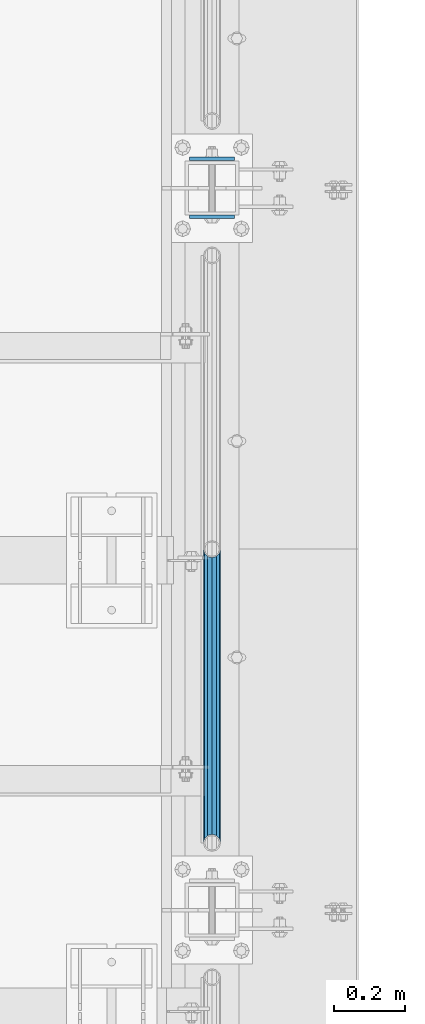
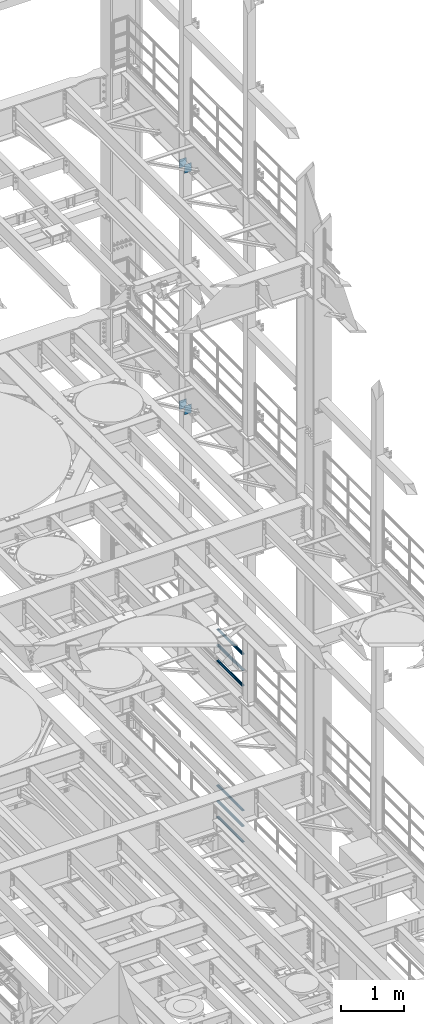
# One storey, part 1346 of 1876: 10 beams, 4 elements without a shape of their own.
"""IFC2X3 building model written with IfcOpenShell, lengths in millimetres."""

from ifc_helpers import new_model, si_unit, frame, origin_with_axes, place, context, subcontext, project, spatial, faceted_brep, material, type_object, element, aggregate, save


model = new_model("IFC2X3")

# Units and contexts
model_context = context("Model", 3, precision=1e-05, world=origin_with_axes())
body_context = subcontext(model_context, "Body", "Model", "MODEL_VIEW")
ifc_project = project(units=[si_unit("LENGTHUNIT", "METRE", prefix="MILLI"), si_unit("AREAUNIT", "SQUARE_METRE"), si_unit("VOLUMEUNIT", "CUBIC_METRE"), si_unit("MASSUNIT", "GRAM", prefix="KILO"), si_unit("TIMEUNIT", "SECOND"), si_unit("PLANEANGLEUNIT", "RADIAN"), si_unit("SOLIDANGLEUNIT", "STERADIAN"), si_unit("THERMODYNAMICTEMPERATUREUNIT", "DEGREE_CELSIUS"), si_unit("LUMINOUSINTENSITYUNIT", "LUMEN")], contexts=[model_context])

# Site, building, storey
site_placement = place(None, origin_with_axes())
site = spatial("IfcSite", under=ifc_project, at=site_placement, CompositionType="ELEMENT")
building_placement = place(site_placement, origin_with_axes())
building = spatial("IfcBuilding", under=site, at=building_placement, Name="Undefined", CompositionType="ELEMENT")
storey_placement = place(building_placement, origin_with_axes())
storey = spatial("IfcBuildingStorey", under=building, at=storey_placement, Name="Undefined", CompositionType="ELEMENT", Elevation=0.0)

# Assembly, beams
assembly_1_placement = place(storey_placement, origin_with_axes())
assembly_1 = element("IfcElementAssembly", 1, at=assembly_1_placement, inside=storey, Name="RAIL", AssemblyPlace="NOTDEFINED", PredefinedType="RIGID_FRAME")
ifc_material_1 = material()
beam_type_1 = type_object("IfcBeamType", Name="PIPE1-1/2SCH40", PredefinedType="NOTDEFINED")
beam_1_placement = place(assembly_1_placement, frame((7620.0, 10668.0, 8315.325), z_axis=(0.0, 0.0, 1.0), x_axis=(0.0, -1.0, 0.0)))
beam_1 = element("IfcBeam", 2, at=beam_1_placement, type_object=beam_type_1, material=ifc_material_1, Name="RAIL", ObjectType="PIPE1-1/2SCH40", context=body_context, shape_type="Brep", body=[
    faceted_brep([(805.872807006681, -12.0649999999996, 20.8971929933177), (805.872807006683, -12.0649999999996, 15.8661214311796), (805.379378568819, -10.2235000000001, 17.7076214311819), (802.640000000001, 0.0, 20.4470000000001), (802.640000000001, 0.0, 24.130000000001), (805.379378568819, 10.2235000000001, 17.7076214311819), (805.872807006683, 12.0649999999996, 15.8661214311796), (805.872807006681, 12.0649999999996, 20.8971929933177), (826.77, 24.1300000000001, 0.0), (814.705, 20.8971929933186, 12.0649999999987), (814.705, 20.8971929933186, -12.0649999999987), (811.515428437862, 17.7076214311801, 10.2235000000001), (814.254807006682, 20.4470000000001, 0.0), (811.515428437862, 17.7076214311801, -10.2235000000001), (805.872807006683, 12.0649999999996, -15.8661214311796), (805.872807006681, 12.0649999999996, -20.8971929933177), (805.379378568819, 10.2235000000001, -17.7076214311819), (802.640000000001, 0.0, -20.4470000000001), (802.640000000001, 0.0, -24.130000000001), (805.872807006683, -12.0649999999996, -15.8661214311796), (805.872807006681, -12.0649999999996, -20.8971929933177), (805.379378568819, -10.2235000000001, -17.7076214311819), (826.77, -24.1300000000001, 0.0), (814.705, -20.8971929933186, -12.0649999999987), (814.705, -20.8971929933186, 12.0649999999987), (811.515428437862, -17.7076214311801, -10.2235000000001), (814.254807006682, -20.4470000000001, 0.0), (811.515428437862, -17.7076214311801, 10.2235000000001), (12.0650000000064, -20.8971929933177, -12.0649999999987), (20.8971929933249, -12.0650000000005, -20.8971929933177), (0.0, 24.1299999999992, 0.0), (12.0650000000064, 20.8971929933177, -12.0649999999987), (12.0650000000064, 20.8971929933177, 12.0649999999987), (20.8971929933249, 12.0650000000005, 20.8971929933177), (24.1300000000064, 0.0, 24.130000000001), (20.8971929933249, 12.0650000000005, -20.8971929933177), (24.1300000000063, 0.0, -24.130000000001), (24.1300000000063, 0.0, -20.4470000000001), (20.8971929933249, -12.0650000000005, -15.8661214311796), (21.3906214311868, -10.2235000000001, -17.7076214311819), (21.3906214311868, 10.2235000000001, -17.7076214311819), (20.8971929933249, 12.0650000000005, -15.8661214311796), (15.2545715621445, 17.7076214311801, -10.2235000000001), (12.5151929933249, 20.4470000000001, 0.0), (15.2545715621445, 17.7076214311801, 10.2235000000001), (20.8971929933249, 12.0650000000005, 15.8661214311796), (21.3906214311868, 10.2235000000001, 17.7076214311819), (24.1300000000064, 0.0, 20.4470000000001), (21.3906214311868, -10.2235000000001, 17.7076214311819), (20.8971929933249, -12.0650000000005, 15.8661214311796), (20.8971929933249, -12.0650000000005, 20.8971929933177), (12.0650000000064, -20.8971929933177, 12.0649999999987), (0.0, -24.1299999999992, 0.0), (15.2545715621445, -17.7076214311801, 10.2235000000001), (12.5151929933249, -20.4470000000001, 0.0), (15.2545715621445, -17.7076214311801, -10.2235000000001)], [[[0, 1, 2, 3, 4]], [[4, 3, 5, 6, 7]], [[8, 9, 10]], [[7, 6, 11, 12, 13, 14, 15, 10, 9]], [[16, 17, 18, 15, 14]], [[19, 20, 18, 17, 21]], [[22, 23, 24]], [[24, 23, 20, 19, 25, 26, 27, 1, 0]], [[28, 29, 20, 23]], [[30, 31, 32]], [[33, 34, 4, 7]], [[32, 33, 7, 9]], [[30, 32, 9, 8]], [[31, 30, 8, 10]], [[35, 31, 10, 15]], [[36, 35, 15, 18]], [[29, 36, 18, 20]], [[37, 36, 29, 38, 39]], [[40, 41, 35, 36, 37]], [[32, 31, 35, 41, 42, 43, 44, 45, 33]], [[33, 45, 46, 47, 34]], [[34, 47, 48, 49, 50]], [[34, 50, 0, 4]], [[50, 51, 24, 0]], [[51, 52, 22, 24]], [[52, 28, 23, 22]], [[51, 28, 52]], [[50, 49, 53, 54, 55, 38, 29, 28, 51]], [[55, 54, 26, 25]], [[21, 39, 38, 55, 25, 19]], [[37, 39, 21, 17]], [[40, 37, 17, 16]], [[42, 41, 40, 16, 14, 13]], [[43, 42, 13, 12]], [[44, 43, 12, 11]], [[5, 46, 45, 44, 11, 6]], [[47, 46, 5, 3]], [[48, 47, 3, 2]], [[53, 49, 48, 2, 1, 27]], [[54, 53, 27, 26]]]),
])
beam_2_placement = place(assembly_1_placement, frame((7620.0, 9841.23, 8620.125), z_axis=(0.0, 0.0, -1.0), x_axis=(0.0, 1.0, 0.0)))
beam_2 = element("IfcBeam", 3, at=beam_2_placement, type_object=beam_type_1, material=ifc_material_1, Name="RAIL", ObjectType="PIPE1-1/2SCH40", context=body_context, shape_type="Brep", body=[
    faceted_brep([(0.0, 24.1299999999992, 0.0), (12.0650000000064, 20.8971929933177, -12.0649999999987), (12.0650000000064, 20.8971929933177, 12.0649999999987), (12.0650000000064, -20.8971929933177, 12.0649999999987), (12.0650000000064, -20.8971929933177, -12.0649999999987), (0.0, -24.1299999999992, 0.0), (20.8971929933249, -12.0650000000005, 20.8971929933177), (20.8971929933249, -12.0650000000005, 15.8661214311796), (15.2545715621445, -17.7076214311801, 10.2235000000001), (12.5151929933249, -20.4470000000001, 0.0), (15.2545715621445, -17.7076214311801, -10.2235000000001), (20.8971929933249, -12.0650000000005, -15.8661214311796), (20.8971929933249, -12.0650000000005, -20.8971929933177), (24.1300000000063, 0.0, -20.4470000000001), (24.1300000000063, 0.0, -24.130000000001), (21.3906214311868, -10.2235000000001, -17.7076214311819), (21.3906214311868, 10.2235000000001, -17.7076214311819), (20.8971929933249, 12.0650000000005, -15.8661214311796), (20.8971929933249, 12.0650000000005, -20.8971929933177), (15.2545715621445, 17.7076214311801, -10.2235000000001), (12.5151929933249, 20.4470000000001, 0.0), (15.2545715621445, 17.7076214311801, 10.2235000000001), (20.8971929933249, 12.0650000000005, 15.8661214311796), (20.8971929933249, 12.0650000000005, 20.8971929933177), (21.3906214311868, 10.2235000000001, 17.7076214311819), (24.1300000000064, 0.0, 20.4470000000001), (24.1300000000064, 0.0, 24.130000000001), (21.3906214311868, -10.2235000000001, 17.7076214311819), (826.77, 24.1300000000001, 0.0), (814.705, 20.8971929933186, -12.0649999999987), (805.872807006681, 12.0649999999996, -20.8971929933177), (826.77, -24.1300000000001, 0.0), (814.705, -20.8971929933186, -12.0649999999987), (814.705, -20.8971929933186, 12.0649999999987), (805.872807006681, -12.0649999999996, 20.8971929933177), (805.872807006681, -12.0649999999996, -20.8971929933177), (802.640000000001, 0.0, -24.130000000001), (805.379378568819, 10.2235000000001, -17.7076214311819), (802.640000000001, 0.0, -20.4470000000001), (805.872807006683, 12.0649999999996, -15.8661214311796), (805.872807006683, -12.0649999999996, -15.8661214311796), (805.379378568819, -10.2235000000001, -17.7076214311819), (811.515428437862, -17.7076214311801, -10.2235000000001), (814.254807006682, -20.4470000000001, 0.0), (811.515428437862, -17.7076214311801, 10.2235000000001), (805.872807006683, -12.0649999999996, 15.8661214311796), (805.379378568819, -10.2235000000001, 17.7076214311819), (802.640000000001, 0.0, 20.4470000000001), (802.640000000001, 0.0, 24.130000000001), (805.872807006681, 12.0649999999996, 20.8971929933177), (814.705, 20.8971929933186, 12.0649999999987), (805.872807006683, 12.0649999999996, 15.8661214311796), (811.515428437862, 17.7076214311801, 10.2235000000001), (814.254807006682, 20.4470000000001, 0.0), (811.515428437862, 17.7076214311801, -10.2235000000001), (805.379378568819, 10.2235000000001, 17.7076214311819)], [[[0, 1, 2]], [[3, 4, 5]], [[6, 7, 8, 9, 10, 11, 12, 4, 3]], [[13, 14, 12, 11, 15]], [[16, 17, 18, 14, 13]], [[2, 1, 18, 17, 19, 20, 21, 22, 23]], [[23, 22, 24, 25, 26]], [[26, 25, 27, 7, 6]], [[1, 0, 28, 29]], [[18, 1, 29, 30]], [[31, 32, 33]], [[6, 3, 33, 34]], [[3, 5, 31, 33]], [[5, 4, 32, 31]], [[4, 12, 35, 32]], [[12, 14, 36, 35]], [[14, 18, 30, 36]], [[37, 38, 36, 30, 39]], [[40, 35, 36, 38, 41]], [[33, 32, 35, 40, 42, 43, 44, 45, 34]], [[34, 45, 46, 47, 48]], [[26, 6, 34, 48]], [[2, 23, 49, 50]], [[23, 26, 48, 49]], [[0, 2, 50, 28]], [[28, 50, 29]], [[49, 51, 52, 53, 54, 39, 30, 29, 50]], [[48, 47, 55, 51, 49]], [[25, 24, 55, 47]], [[55, 24, 22, 21, 52, 51]], [[21, 20, 53, 52]], [[20, 19, 54, 53]], [[19, 17, 16, 37, 39, 54]], [[16, 13, 38, 37]], [[13, 15, 41, 38]], [[41, 15, 11, 10, 42, 40]], [[10, 9, 43, 42]], [[9, 8, 44, 43]], [[8, 7, 27, 46, 45, 44]], [[27, 25, 47, 46]]]),
])
beam_3_placement = place(assembly_1_placement, frame((7620.0, 9841.23, 8924.925), z_axis=(0.0, 0.0, -1.0), x_axis=(0.0, 1.0, 0.0)))
beam_3 = element("IfcBeam", 4, at=beam_3_placement, type_object=beam_type_1, material=ifc_material_1, Name="RAIL", ObjectType="PIPE1-1/2SCH40", context=body_context, shape_type="Brep", body=[
    faceted_brep([(0.0, 24.1299999999992, 0.0), (12.0650000000064, 20.8971929933177, -12.0649999999987), (12.0650000000064, 20.8971929933177, 12.0649999999987), (12.0650000000064, -20.8971929933177, 12.0649999999987), (12.0650000000064, -20.8971929933177, -12.0649999999987), (0.0, -24.1299999999992, 0.0), (20.8971929933249, -12.0650000000005, 20.8971929933177), (20.8971929933249, -12.0650000000005, 15.8661214311796), (15.2545715621445, -17.7076214311801, 10.2235000000001), (12.5151929933249, -20.4470000000001, 0.0), (15.2545715621445, -17.7076214311801, -10.2235000000001), (20.8971929933249, -12.0650000000005, -15.8661214311796), (20.8971929933249, -12.0650000000005, -20.8971929933177), (24.1300000000063, 0.0, -20.4470000000001), (24.1300000000063, 0.0, -24.130000000001), (21.3906214311868, -10.2235000000001, -17.7076214311819), (21.3906214311868, 10.2235000000001, -17.7076214311819), (20.8971929933249, 12.0650000000005, -15.8661214311796), (20.8971929933249, 12.0650000000005, -20.8971929933177), (15.2545715621445, 17.7076214311801, -10.2235000000001), (12.5151929933249, 20.4470000000001, 0.0), (15.2545715621445, 17.7076214311801, 10.2235000000001), (20.8971929933249, 12.0650000000005, 15.8661214311796), (20.8971929933249, 12.0650000000005, 20.8971929933177), (21.3906214311868, 10.2235000000001, 17.7076214311819), (24.1300000000064, 0.0, 20.4470000000001), (24.1300000000064, 0.0, 24.130000000001), (21.3906214311868, -10.2235000000001, 17.7076214311819), (826.77, 24.1300000000001, 0.0), (814.705, 20.8971929933186, -12.0649999999987), (805.872807006681, 12.0649999999996, -20.8971929933177), (826.77, -24.1300000000001, 0.0), (814.705, -20.8971929933186, -12.0649999999987), (814.705, -20.8971929933186, 12.0649999999987), (805.872807006681, -12.0649999999996, 20.8971929933177), (805.872807006681, -12.0649999999996, -20.8971929933177), (802.640000000001, 0.0, -24.130000000001), (805.379378568819, 10.2235000000001, -17.7076214311819), (802.640000000001, 0.0, -20.4470000000001), (805.872807006683, 12.0649999999996, -15.8661214311796), (805.872807006683, -12.0649999999996, -15.8661214311796), (805.379378568819, -10.2235000000001, -17.7076214311819), (811.515428437862, -17.7076214311801, -10.2235000000001), (814.254807006682, -20.4470000000001, 0.0), (811.515428437862, -17.7076214311801, 10.2235000000001), (805.872807006683, -12.0649999999996, 15.8661214311796), (805.379378568819, -10.2235000000001, 17.7076214311819), (802.640000000001, 0.0, 20.4470000000001), (802.640000000001, 0.0, 24.130000000001), (805.872807006681, 12.0649999999996, 20.8971929933177), (814.705, 20.8971929933186, 12.0649999999987), (805.872807006683, 12.0649999999996, 15.8661214311796), (811.515428437862, 17.7076214311801, 10.2235000000001), (814.254807006682, 20.4470000000001, 0.0), (811.515428437862, 17.7076214311801, -10.2235000000001), (805.379378568819, 10.2235000000001, 17.7076214311819)], [[[0, 1, 2]], [[3, 4, 5]], [[6, 7, 8, 9, 10, 11, 12, 4, 3]], [[13, 14, 12, 11, 15]], [[16, 17, 18, 14, 13]], [[2, 1, 18, 17, 19, 20, 21, 22, 23]], [[23, 22, 24, 25, 26]], [[26, 25, 27, 7, 6]], [[1, 0, 28, 29]], [[18, 1, 29, 30]], [[31, 32, 33]], [[6, 3, 33, 34]], [[3, 5, 31, 33]], [[5, 4, 32, 31]], [[4, 12, 35, 32]], [[12, 14, 36, 35]], [[14, 18, 30, 36]], [[37, 38, 36, 30, 39]], [[40, 35, 36, 38, 41]], [[33, 32, 35, 40, 42, 43, 44, 45, 34]], [[34, 45, 46, 47, 48]], [[26, 6, 34, 48]], [[2, 23, 49, 50]], [[23, 26, 48, 49]], [[0, 2, 50, 28]], [[28, 50, 29]], [[49, 51, 52, 53, 54, 39, 30, 29, 50]], [[48, 47, 55, 51, 49]], [[25, 24, 55, 47]], [[55, 24, 22, 21, 52, 51]], [[21, 20, 53, 52]], [[20, 19, 54, 53]], [[19, 17, 16, 37, 39, 54]], [[16, 13, 38, 37]], [[13, 15, 41, 38]], [[41, 15, 11, 10, 42, 40]], [[10, 9, 43, 42]], [[9, 8, 44, 43]], [[8, 7, 27, 46, 45, 44]], [[27, 25, 47, 46]]]),
])
aggregate(assembly_1, [beam_1, beam_2, beam_3])

assembly_2_placement = place(storey_placement, origin_with_axes())
assembly_2 = element("IfcElementAssembly", 5, at=assembly_2_placement, inside=storey, Name="RAIL", AssemblyPlace="NOTDEFINED", PredefinedType="RIGID_FRAME")
beam_4_placement = place(assembly_2_placement, frame((7620.0, 10668.0, 5292.725), z_axis=(0.0, 0.0, 1.0), x_axis=(0.0, -1.0, 0.0)))
beam_4 = element("IfcBeam", 6, at=beam_4_placement, type_object=beam_type_1, material=ifc_material_1, Name="RAIL", ObjectType="PIPE1-1/2SCH40", context=body_context, shape_type="Brep", body=[
    faceted_brep([(805.872807006681, -12.0649999999996, 20.8971929933177), (805.872807006683, -12.0649999999996, 15.8661214311796), (805.379378568819, -10.2235000000001, 17.7076214311819), (802.640000000001, 0.0, 20.4470000000001), (802.640000000001, 0.0, 24.130000000001), (805.379378568819, 10.2235000000001, 17.7076214311819), (805.872807006683, 12.0649999999996, 15.8661214311796), (805.872807006681, 12.0649999999996, 20.8971929933177), (826.77, 24.1300000000001, 0.0), (814.705, 20.8971929933186, 12.0649999999987), (814.705, 20.8971929933186, -12.0649999999987), (811.515428437862, 17.7076214311801, 10.2235000000001), (814.254807006682, 20.4470000000001, 0.0), (811.515428437862, 17.7076214311801, -10.2235000000001), (805.872807006683, 12.0649999999996, -15.8661214311796), (805.872807006681, 12.0649999999996, -20.8971929933177), (805.379378568819, 10.2235000000001, -17.7076214311819), (802.640000000001, 0.0, -20.4470000000001), (802.640000000001, 0.0, -24.130000000001), (805.872807006683, -12.0649999999996, -15.8661214311796), (805.872807006681, -12.0649999999996, -20.8971929933177), (805.379378568819, -10.2235000000001, -17.7076214311819), (826.77, -24.1300000000001, 0.0), (814.705, -20.8971929933186, -12.0649999999987), (814.705, -20.8971929933186, 12.0649999999987), (811.515428437862, -17.7076214311801, -10.2235000000001), (814.254807006682, -20.4470000000001, 0.0), (811.515428437862, -17.7076214311801, 10.2235000000001), (12.0650000000064, -20.8971929933177, -12.0649999999987), (20.8971929933249, -12.0650000000005, -20.8971929933177), (0.0, 24.1299999999992, 0.0), (12.0650000000064, 20.8971929933177, -12.0649999999987), (12.0650000000064, 20.8971929933177, 12.0649999999987), (20.8971929933249, 12.0650000000005, 20.8971929933177), (24.1300000000064, 0.0, 24.130000000001), (20.8971929933249, 12.0650000000005, -20.8971929933177), (24.1300000000063, 0.0, -24.130000000001), (24.1300000000063, 0.0, -20.4470000000001), (20.8971929933249, -12.0650000000005, -15.8661214311796), (21.3906214311868, -10.2235000000001, -17.7076214311819), (21.3906214311868, 10.2235000000001, -17.7076214311819), (20.8971929933249, 12.0650000000005, -15.8661214311796), (15.2545715621445, 17.7076214311801, -10.2235000000001), (12.5151929933249, 20.4470000000001, 0.0), (15.2545715621445, 17.7076214311801, 10.2235000000001), (20.8971929933249, 12.0650000000005, 15.8661214311796), (21.3906214311868, 10.2235000000001, 17.7076214311819), (24.1300000000064, 0.0, 20.4470000000001), (21.3906214311868, -10.2235000000001, 17.7076214311819), (20.8971929933249, -12.0650000000005, 15.8661214311796), (20.8971929933249, -12.0650000000005, 20.8971929933177), (12.0650000000064, -20.8971929933177, 12.0649999999987), (0.0, -24.1299999999992, 0.0), (15.2545715621445, -17.7076214311801, 10.2235000000001), (12.5151929933249, -20.4470000000001, 0.0), (15.2545715621445, -17.7076214311801, -10.2235000000001)], [[[0, 1, 2, 3, 4]], [[4, 3, 5, 6, 7]], [[8, 9, 10]], [[7, 6, 11, 12, 13, 14, 15, 10, 9]], [[16, 17, 18, 15, 14]], [[19, 20, 18, 17, 21]], [[22, 23, 24]], [[24, 23, 20, 19, 25, 26, 27, 1, 0]], [[28, 29, 20, 23]], [[30, 31, 32]], [[33, 34, 4, 7]], [[32, 33, 7, 9]], [[30, 32, 9, 8]], [[31, 30, 8, 10]], [[35, 31, 10, 15]], [[36, 35, 15, 18]], [[29, 36, 18, 20]], [[37, 36, 29, 38, 39]], [[40, 41, 35, 36, 37]], [[32, 31, 35, 41, 42, 43, 44, 45, 33]], [[33, 45, 46, 47, 34]], [[34, 47, 48, 49, 50]], [[34, 50, 0, 4]], [[50, 51, 24, 0]], [[51, 52, 22, 24]], [[52, 28, 23, 22]], [[51, 28, 52]], [[50, 49, 53, 54, 55, 38, 29, 28, 51]], [[55, 54, 26, 25]], [[21, 39, 38, 55, 25, 19]], [[37, 39, 21, 17]], [[40, 37, 17, 16]], [[42, 41, 40, 16, 14, 13]], [[43, 42, 13, 12]], [[44, 43, 12, 11]], [[5, 46, 45, 44, 11, 6]], [[47, 46, 5, 3]], [[48, 47, 3, 2]], [[53, 49, 48, 2, 1, 27]], [[54, 53, 27, 26]]]),
])
beam_5_placement = place(assembly_2_placement, frame((7620.0, 9841.23, 5597.525), z_axis=(0.0, 0.0, -1.0), x_axis=(0.0, 1.0, 0.0)))
beam_5 = element("IfcBeam", 7, at=beam_5_placement, type_object=beam_type_1, material=ifc_material_1, Name="RAIL", ObjectType="PIPE1-1/2SCH40", context=body_context, shape_type="Brep", body=[
    faceted_brep([(0.0, 24.1299999999992, 0.0), (12.0650000000064, 20.8971929933177, -12.0649999999987), (12.0650000000064, 20.8971929933177, 12.0649999999987), (12.0650000000064, -20.8971929933177, 12.0649999999987), (12.0650000000064, -20.8971929933177, -12.0649999999987), (0.0, -24.1299999999992, 0.0), (20.8971929933249, -12.0650000000005, 20.8971929933177), (20.8971929933249, -12.0650000000005, 15.8661214311796), (15.2545715621445, -17.7076214311801, 10.2235000000001), (12.5151929933249, -20.4470000000001, 0.0), (15.2545715621445, -17.7076214311801, -10.2235000000001), (20.8971929933249, -12.0650000000005, -15.8661214311796), (20.8971929933249, -12.0650000000005, -20.8971929933177), (24.1300000000063, 0.0, -20.4470000000001), (24.1300000000063, 0.0, -24.130000000001), (21.3906214311868, -10.2235000000001, -17.7076214311819), (21.3906214311868, 10.2235000000001, -17.7076214311819), (20.8971929933249, 12.0650000000005, -15.8661214311796), (20.8971929933249, 12.0650000000005, -20.8971929933177), (15.2545715621445, 17.7076214311801, -10.2235000000001), (12.5151929933249, 20.4470000000001, 0.0), (15.2545715621445, 17.7076214311801, 10.2235000000001), (20.8971929933249, 12.0650000000005, 15.8661214311796), (20.8971929933249, 12.0650000000005, 20.8971929933177), (21.3906214311868, 10.2235000000001, 17.7076214311819), (24.1300000000064, 0.0, 20.4470000000001), (24.1300000000064, 0.0, 24.130000000001), (21.3906214311868, -10.2235000000001, 17.7076214311819), (826.77, 24.1300000000001, 0.0), (814.705, 20.8971929933186, -12.0649999999987), (805.872807006681, 12.0649999999996, -20.8971929933177), (826.77, -24.1300000000001, 0.0), (814.705, -20.8971929933186, -12.0649999999987), (814.705, -20.8971929933186, 12.0649999999987), (805.872807006681, -12.0649999999996, 20.8971929933177), (805.872807006681, -12.0649999999996, -20.8971929933177), (802.640000000001, 0.0, -24.130000000001), (805.379378568819, 10.2235000000001, -17.7076214311819), (802.640000000001, 0.0, -20.4470000000001), (805.872807006683, 12.0649999999996, -15.8661214311796), (805.872807006683, -12.0649999999996, -15.8661214311796), (805.379378568819, -10.2235000000001, -17.7076214311819), (811.515428437862, -17.7076214311801, -10.2235000000001), (814.254807006682, -20.4470000000001, 0.0), (811.515428437862, -17.7076214311801, 10.2235000000001), (805.872807006683, -12.0649999999996, 15.8661214311796), (805.379378568819, -10.2235000000001, 17.7076214311819), (802.640000000001, 0.0, 20.4470000000001), (802.640000000001, 0.0, 24.130000000001), (805.872807006681, 12.0649999999996, 20.8971929933177), (814.705, 20.8971929933186, 12.0649999999987), (805.872807006683, 12.0649999999996, 15.8661214311796), (811.515428437862, 17.7076214311801, 10.2235000000001), (814.254807006682, 20.4470000000001, 0.0), (811.515428437862, 17.7076214311801, -10.2235000000001), (805.379378568819, 10.2235000000001, 17.7076214311819)], [[[0, 1, 2]], [[3, 4, 5]], [[6, 7, 8, 9, 10, 11, 12, 4, 3]], [[13, 14, 12, 11, 15]], [[16, 17, 18, 14, 13]], [[2, 1, 18, 17, 19, 20, 21, 22, 23]], [[23, 22, 24, 25, 26]], [[26, 25, 27, 7, 6]], [[1, 0, 28, 29]], [[18, 1, 29, 30]], [[31, 32, 33]], [[6, 3, 33, 34]], [[3, 5, 31, 33]], [[5, 4, 32, 31]], [[4, 12, 35, 32]], [[12, 14, 36, 35]], [[14, 18, 30, 36]], [[37, 38, 36, 30, 39]], [[40, 35, 36, 38, 41]], [[33, 32, 35, 40, 42, 43, 44, 45, 34]], [[34, 45, 46, 47, 48]], [[26, 6, 34, 48]], [[2, 23, 49, 50]], [[23, 26, 48, 49]], [[0, 2, 50, 28]], [[28, 50, 29]], [[49, 51, 52, 53, 54, 39, 30, 29, 50]], [[48, 47, 55, 51, 49]], [[25, 24, 55, 47]], [[55, 24, 22, 21, 52, 51]], [[21, 20, 53, 52]], [[20, 19, 54, 53]], [[19, 17, 16, 37, 39, 54]], [[16, 13, 38, 37]], [[13, 15, 41, 38]], [[41, 15, 11, 10, 42, 40]], [[10, 9, 43, 42]], [[9, 8, 44, 43]], [[8, 7, 27, 46, 45, 44]], [[27, 25, 47, 46]]]),
])
beam_6_placement = place(assembly_2_placement, frame((7620.0, 9841.23, 5902.325), z_axis=(0.0, 0.0, -1.0), x_axis=(0.0, 1.0, 0.0)))
beam_6 = element("IfcBeam", 8, at=beam_6_placement, type_object=beam_type_1, material=ifc_material_1, Name="RAIL", ObjectType="PIPE1-1/2SCH40", context=body_context, shape_type="Brep", body=[
    faceted_brep([(0.0, 24.1299999999992, 0.0), (12.0650000000064, 20.8971929933177, -12.0649999999987), (12.0650000000064, 20.8971929933177, 12.0649999999987), (12.0650000000064, -20.8971929933177, 12.0649999999987), (12.0650000000064, -20.8971929933177, -12.0649999999987), (0.0, -24.1299999999992, 0.0), (20.8971929933249, -12.0650000000005, 20.8971929933177), (20.8971929933249, -12.0650000000005, 15.8661214311796), (15.2545715621445, -17.7076214311801, 10.2235000000001), (12.5151929933249, -20.4470000000001, 0.0), (15.2545715621445, -17.7076214311801, -10.2235000000001), (20.8971929933249, -12.0650000000005, -15.8661214311796), (20.8971929933249, -12.0650000000005, -20.8971929933177), (24.1300000000063, 0.0, -20.4470000000001), (24.1300000000063, 0.0, -24.130000000001), (21.3906214311868, -10.2235000000001, -17.7076214311819), (21.3906214311868, 10.2235000000001, -17.7076214311819), (20.8971929933249, 12.0650000000005, -15.8661214311796), (20.8971929933249, 12.0650000000005, -20.8971929933177), (15.2545715621445, 17.7076214311801, -10.2235000000001), (12.5151929933249, 20.4470000000001, 0.0), (15.2545715621445, 17.7076214311801, 10.2235000000001), (20.8971929933249, 12.0650000000005, 15.8661214311796), (20.8971929933249, 12.0650000000005, 20.8971929933177), (21.3906214311868, 10.2235000000001, 17.7076214311819), (24.1300000000064, 0.0, 20.4470000000001), (24.1300000000064, 0.0, 24.130000000001), (21.3906214311868, -10.2235000000001, 17.7076214311819), (826.77, 24.1300000000001, 0.0), (814.705, 20.8971929933186, -12.0649999999987), (805.872807006681, 12.0649999999996, -20.8971929933177), (826.77, -24.1300000000001, 0.0), (814.705, -20.8971929933186, -12.0649999999987), (814.705, -20.8971929933186, 12.0649999999987), (805.872807006681, -12.0649999999996, 20.8971929933177), (805.872807006681, -12.0649999999996, -20.8971929933177), (802.640000000001, 0.0, -24.130000000001), (805.379378568819, 10.2235000000001, -17.7076214311819), (802.640000000001, 0.0, -20.4470000000001), (805.872807006683, 12.0649999999996, -15.8661214311796), (805.872807006683, -12.0649999999996, -15.8661214311796), (805.379378568819, -10.2235000000001, -17.7076214311819), (811.515428437862, -17.7076214311801, -10.2235000000001), (814.254807006682, -20.4470000000001, 0.0), (811.515428437862, -17.7076214311801, 10.2235000000001), (805.872807006683, -12.0649999999996, 15.8661214311796), (805.379378568819, -10.2235000000001, 17.7076214311819), (802.640000000001, 0.0, 20.4470000000001), (802.640000000001, 0.0, 24.130000000001), (805.872807006681, 12.0649999999996, 20.8971929933177), (814.705, 20.8971929933186, 12.0649999999987), (805.872807006683, 12.0649999999996, 15.8661214311796), (811.515428437862, 17.7076214311801, 10.2235000000001), (814.254807006682, 20.4470000000001, 0.0), (811.515428437862, 17.7076214311801, -10.2235000000001), (805.379378568819, 10.2235000000001, 17.7076214311819)], [[[0, 1, 2]], [[3, 4, 5]], [[6, 7, 8, 9, 10, 11, 12, 4, 3]], [[13, 14, 12, 11, 15]], [[16, 17, 18, 14, 13]], [[2, 1, 18, 17, 19, 20, 21, 22, 23]], [[23, 22, 24, 25, 26]], [[26, 25, 27, 7, 6]], [[1, 0, 28, 29]], [[18, 1, 29, 30]], [[31, 32, 33]], [[6, 3, 33, 34]], [[3, 5, 31, 33]], [[5, 4, 32, 31]], [[4, 12, 35, 32]], [[12, 14, 36, 35]], [[14, 18, 30, 36]], [[37, 38, 36, 30, 39]], [[40, 35, 36, 38, 41]], [[33, 32, 35, 40, 42, 43, 44, 45, 34]], [[34, 45, 46, 47, 48]], [[26, 6, 34, 48]], [[2, 23, 49, 50]], [[23, 26, 48, 49]], [[0, 2, 50, 28]], [[28, 50, 29]], [[49, 51, 52, 53, 54, 39, 30, 29, 50]], [[48, 47, 55, 51, 49]], [[25, 24, 55, 47]], [[55, 24, 22, 21, 52, 51]], [[21, 20, 53, 52]], [[20, 19, 54, 53]], [[19, 17, 16, 37, 39, 54]], [[16, 13, 38, 37]], [[13, 15, 41, 38]], [[41, 15, 11, 10, 42, 40]], [[10, 9, 43, 42]], [[9, 8, 44, 43]], [[8, 7, 27, 46, 45, 44]], [[27, 25, 47, 46]]]),
])
aggregate(assembly_2, [beam_4, beam_5, beam_6])

assembly_3_placement = place(storey_placement, origin_with_axes())
assembly_3 = element("IfcElementAssembly", 9, at=assembly_3_placement, inside=storey, Name="BEAM", AssemblyPlace="NOTDEFINED", PredefinedType="RIGID_FRAME")
ifc_material_2 = material(Name="STEEL/A36")
beam_type_2 = type_object("IfcBeamType", PredefinedType="NOTDEFINED")
beam_7_placement = place(assembly_3_placement, frame((7556.36848042001, 11766.55, 12604.7488224823), z_axis=(2.95459999824743e-05, 0.0, -0.999999999563517), x_axis=(0.999999999563517, 0.0, 2.95459999828704e-05)))
beam_7 = element("IfcBeam", 10, at=beam_7_placement, type_object=beam_type_2, material=ifc_material_2, Name="PLATE", context=body_context, shape_type="Brep", body=[
    faceted_brep([(0.0, 4.76249999999982, -82.5499999999993), (0.0, 4.76249999999982, 82.5499999999993), (127.0, 4.76249999999982, 82.5499999999993), (127.0, 4.76249999999982, -82.5499999999993), (0.0, -4.76249999999982, 82.5499999999993), (127.0, -4.76249999999982, 82.5499999999993), (0.0, -4.76249999999982, -82.5499999999993), (127.0, -4.76249999999982, -82.5499999999993)], [[[0, 1, 2, 3]], [[1, 4, 5, 2]], [[4, 6, 7, 5]], [[6, 0, 3, 7]], [[5, 7, 3, 2]], [[6, 4, 1, 0]]]),
])
beam_8_placement = place(assembly_3_placement, frame((7556.36848042001, 11603.0375, 12604.7488224823), z_axis=(2.95459999824743e-05, 0.0, -0.999999999563517), x_axis=(0.999999999563517, 0.0, 2.95459999828704e-05)))
beam_8 = element("IfcBeam", 11, at=beam_8_placement, type_object=beam_type_2, material=ifc_material_2, Name="PLATE", context=body_context, shape_type="Brep", body=[
    faceted_brep([(0.0, 4.76249999999982, -82.5499999999993), (0.0, 4.76249999999982, 82.5499999999993), (127.0, 4.76249999999982, 82.5499999999993), (127.0, 4.76249999999982, -82.5499999999993), (0.0, -4.76249999999982, 82.5499999999993), (127.0, -4.76249999999982, 82.5499999999993), (0.0, -4.76249999999982, -82.5499999999993), (127.0, -4.76249999999982, -82.5499999999993)], [[[0, 1, 2, 3]], [[1, 4, 5, 2]], [[4, 6, 7, 5]], [[6, 0, 3, 7]], [[5, 7, 3, 2]], [[6, 4, 1, 0]]]),
])
aggregate(assembly_3, [beam_7, beam_8])

assembly_4_placement = place(storey_placement, origin_with_axes())
assembly_4 = element("IfcElementAssembly", 12, at=assembly_4_placement, inside=storey, Name="BEAM", AssemblyPlace="NOTDEFINED", PredefinedType="RIGID_FRAME")
beam_9_placement = place(assembly_4_placement, frame((7556.5, 11766.55, 17278.35), z_axis=(0.0, 0.0, -1.0), x_axis=(1.0, 0.0, 0.0)))
beam_9 = element("IfcBeam", 13, at=beam_9_placement, type_object=beam_type_2, material=ifc_material_2, Name="PLATE", context=body_context, shape_type="Brep", body=[
    faceted_brep([(0.0, 4.76249999999982, -82.5499999999993), (0.0, 4.76249999999982, 82.5499999999993), (127.0, 4.76249999999982, 82.5499999999993), (127.0, 4.76249999999982, -82.5499999999993), (0.0, -4.76249999999982, 82.5499999999993), (127.0, -4.76249999999982, 82.5499999999993), (0.0, -4.76249999999982, -82.5499999999993), (127.0, -4.76249999999982, -82.5499999999993)], [[[0, 1, 2, 3]], [[1, 4, 5, 2]], [[4, 6, 7, 5]], [[6, 0, 3, 7]], [[5, 7, 3, 2]], [[6, 4, 1, 0]]]),
])
beam_10_placement = place(assembly_4_placement, frame((7556.5, 11603.0375, 17278.35), z_axis=(0.0, 0.0, -1.0), x_axis=(1.0, 0.0, 0.0)))
beam_10 = element("IfcBeam", 14, at=beam_10_placement, type_object=beam_type_2, material=ifc_material_2, Name="PLATE", context=body_context, shape_type="Brep", body=[
    faceted_brep([(0.0, 4.76249999999982, -82.5499999999993), (0.0, 4.76249999999982, 82.5499999999993), (127.0, 4.76249999999982, 82.5499999999993), (127.0, 4.76249999999982, -82.5499999999993), (0.0, -4.76249999999982, 82.5499999999993), (127.0, -4.76249999999982, 82.5499999999993), (0.0, -4.76249999999982, -82.5499999999993), (127.0, -4.76249999999982, -82.5499999999993)], [[[0, 1, 2, 3]], [[1, 4, 5, 2]], [[4, 6, 7, 5]], [[6, 0, 3, 7]], [[5, 7, 3, 2]], [[6, 4, 1, 0]]]),
])
aggregate(assembly_4, [beam_9, beam_10])

save(model, "model.ifc")
